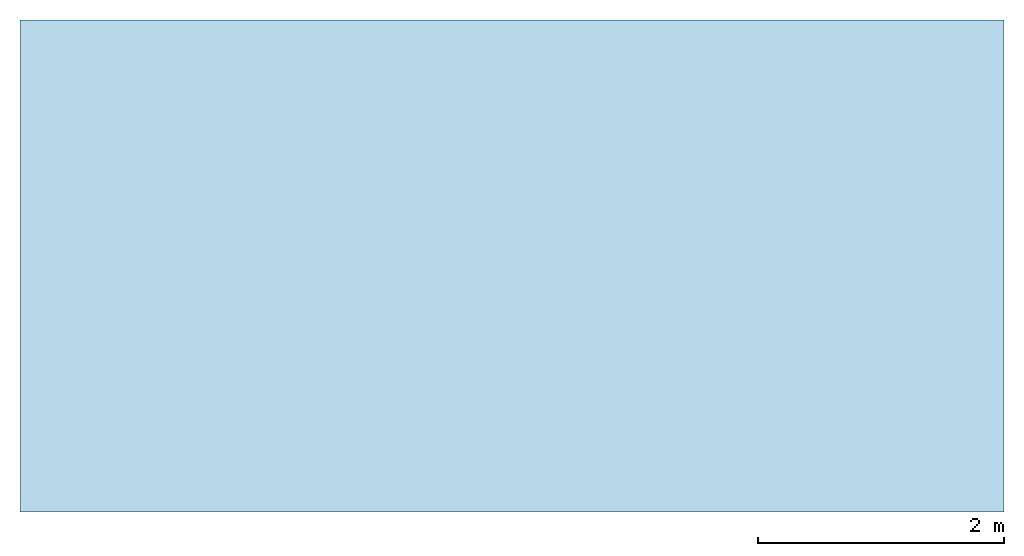
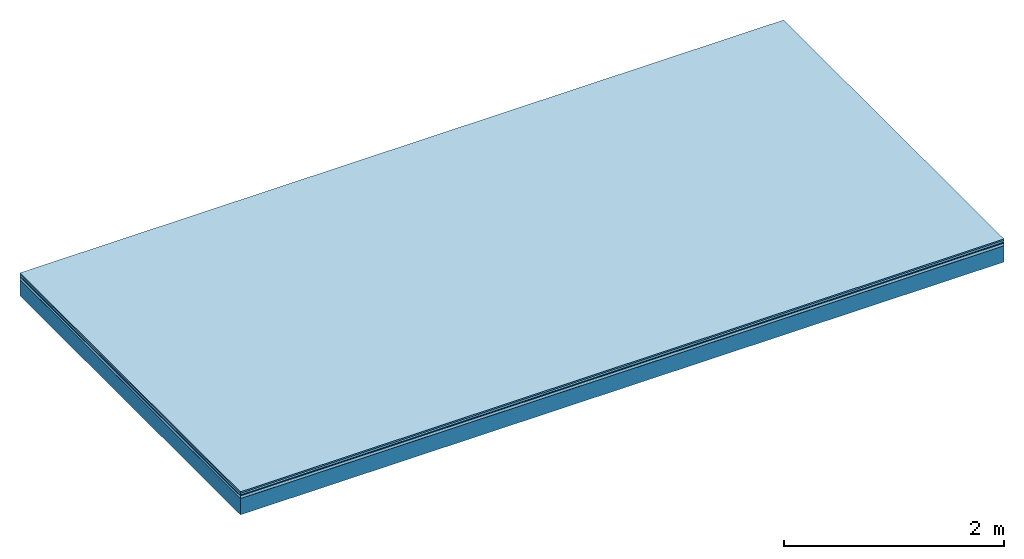
# One storey: 5 plates, 1 member, 1 element without a shape of its own.
"""IFC4 building model written with IfcOpenShell, lengths in metres."""

from ifc_helpers import new_model, si_unit, derived_unit, direction, frame, frame_2d, origin, origin_with_axes, place, context, project, spatial, rectangle, extrude, material, layer, layer_set, type_object, element, aggregate, save


model = new_model("IFC4")

# Units and contexts
plan_context = context("Plan", 3, precision=1e-05, world=origin(), true_north=direction((0.0, 1.0)))
model_context = context("Model", 3, precision=1e-05, world=origin(), true_north=direction((0.0, 1.0)))
ifc_project = project(units=[si_unit("LENGTHUNIT", "METRE"), derived_unit("SOUNDPRESSUREUNIT", [(si_unit("PRESSUREUNIT", "PASCAL", prefix="MICRO"), 0)]), si_unit("ENERGYUNIT", "JOULE", prefix="MEGA"), si_unit("MASSUNIT", "GRAM", prefix="KILO"), derived_unit("THERMALTRANSMITTANCEUNIT", [(si_unit("POWERUNIT", "WATT"), 1), (si_unit("AREAUNIT", "SQUARE_METRE"), -1), (si_unit("THERMODYNAMICTEMPERATUREUNIT", "KELVIN"), -1)]), derived_unit("AREADENSITYUNIT", [(si_unit("MASSUNIT", "GRAM", prefix="KILO"), 1), (si_unit("AREAUNIT", "SQUARE_METRE"), -1)]), derived_unit("USERDEFINED", [(si_unit("ENERGYUNIT", "JOULE", prefix="MEGA"), 1), (si_unit("AREAUNIT", "SQUARE_METRE"), -1)])], contexts=[plan_context, model_context])

# Site, building, storey
site = spatial("IfcSite", under=ifc_project)
building_placement = place(None, origin())
building = spatial("IfcBuilding", under=site, at=building_placement)
storey_placement = place(building_placement, origin())
storey = spatial("IfcBuildingStorey", under=building, at=storey_placement)

# Slab, member, plates
ifc_material_1 = material(Category="11.013")
ifc_layer_1 = layer(ifc_material_1, 0.015, Name="Flooring")
ifc_material_2 = material(Category="03.007")
ifc_layer_2 = layer(ifc_material_2, 0.02, Name="On-material")
ifc_material_3 = material(Name="Wood fiber generic product", Category="10.009")
ifc_layer_3 = layer(ifc_material_3, 0.01, Name="Impact sound insulation")
ifc_material_4 = material(Name="with broken")
ifc_layer_4 = layer(ifc_material_4, 0.03, Name="on Supporting structure")
ifc_material_5 = material(Name="protection", Category="09.007")
ifc_layer_5 = layer(ifc_material_5, 0.0005, Name="Sub-floor")
ifc_material_6 = material(Name="no composite action")
ifc_layer_6 = layer(ifc_material_6, 0.0, Name="Bond")
ifc_layer_7 = layer(None, 0.18, Name="Supporting structure")
ifc_layer_set = layer_set([ifc_layer_1, ifc_layer_2, ifc_layer_3, ifc_layer_4, ifc_layer_5, ifc_layer_6, ifc_layer_7])
slab_type = type_object("IfcSlabType", Name="A2045", PredefinedType="NOTDEFINED", material=ifc_layer_set)
slab_placement = place(None, frame((0.0, 0.0, 0.0), z_axis=(0.0, 0.0, -1.0), x_axis=(1.0, 0.0, 0.0)))
slab = element("IfcSlab", 1, at=slab_placement, inside=storey, type_object=slab_type, material=ifc_layer_set, Name="Slab #1")
ifc_material_7 = material(Name="Solid timber panel")
member_placement = place(slab_placement, origin())
member = element("IfcMember", 2, at=member_placement, material=ifc_material_7, Name="Supporting structure", context=plan_context, shape_type="SweptSolid", body=[
    extrude(rectangle(XDim=1.0, YDim=0.18, at=frame_2d((0.5, 0.09), x_axis=(1.0, 0.0))), frame((0.0, 4.0, 0.0755), z_axis=(0.0, -1.0, 0.0), x_axis=(1.0, 0.0, 0.0)), (0.0, 0.0, 1.0), 4.0),
    extrude(rectangle(XDim=1.0, YDim=0.18, at=frame_2d((0.5, 0.09), x_axis=(1.0, 0.0))), frame((1.0, 4.0, 0.0755), z_axis=(0.0, -1.0, 0.0), x_axis=(1.0, 0.0, 0.0)), (0.0, 0.0, 1.0), 4.0),
    extrude(rectangle(XDim=1.0, YDim=0.18, at=frame_2d((0.5, 0.09), x_axis=(1.0, 0.0))), frame((2.0, 4.0, 0.0755), z_axis=(0.0, -1.0, 0.0), x_axis=(1.0, 0.0, 0.0)), (0.0, 0.0, 1.0), 4.0),
    extrude(rectangle(XDim=1.0, YDim=0.18, at=frame_2d((0.5, 0.09), x_axis=(1.0, 0.0))), frame((3.0, 4.0, 0.0755), z_axis=(0.0, -1.0, 0.0), x_axis=(1.0, 0.0, 0.0)), (0.0, 0.0, 1.0), 4.0),
    extrude(rectangle(XDim=1.0, YDim=0.18, at=frame_2d((0.5, 0.09), x_axis=(1.0, 0.0))), frame((4.0, 4.0, 0.0755), z_axis=(0.0, -1.0, 0.0), x_axis=(1.0, 0.0, 0.0)), (0.0, 0.0, 1.0), 4.0),
    extrude(rectangle(XDim=1.0, YDim=0.18, at=frame_2d((0.5, 0.09), x_axis=(1.0, 0.0))), frame((5.0, 4.0, 0.0755), z_axis=(0.0, -1.0, 0.0), x_axis=(1.0, 0.0, 0.0)), (0.0, 0.0, 1.0), 4.0),
    extrude(rectangle(XDim=1.0, YDim=0.18, at=frame_2d((0.5, 0.09), x_axis=(1.0, 0.0))), frame((6.0, 4.0, 0.0755), z_axis=(0.0, -1.0, 0.0), x_axis=(1.0, 0.0, 0.0)), (0.0, 0.0, 1.0), 4.0),
    extrude(rectangle(XDim=1.0, YDim=0.18, at=frame_2d((0.5, 0.09), x_axis=(1.0, 0.0))), frame((7.0, 4.0, 0.0755), z_axis=(0.0, -1.0, 0.0), x_axis=(1.0, 0.0, 0.0)), (0.0, 0.0, 1.0), 4.0),
])
plate_1_placement = place(slab_placement, origin())
plate_1 = element("IfcPlate", 3, at=plate_1_placement, material=ifc_material_1, Name="Flooring", context=plan_context, shape_type="SweptSolid", body=[
    extrude(rectangle(XDim=8.0, YDim=4.0, at=frame_2d((4.0, 2.0), x_axis=(1.0, 0.0))), origin_with_axes(), (0.0, 0.0, 1.0), 0.015),
])
plate_2_placement = place(slab_placement, origin())
plate_2 = element("IfcPlate", 4, at=plate_2_placement, material=ifc_material_2, Name="On-material", context=plan_context, shape_type="SweptSolid", body=[
    extrude(rectangle(XDim=8.0, YDim=4.0, at=frame_2d((4.0, 2.0), x_axis=(1.0, 0.0))), frame((0.0, 0.0, 0.015), z_axis=(0.0, 0.0, 1.0), x_axis=(1.0, 0.0, 0.0)), (0.0, 0.0, 1.0), 0.02),
])
plate_3_placement = place(slab_placement, origin())
plate_3 = element("IfcPlate", 5, at=plate_3_placement, material=ifc_material_3, Name="Impact sound insulation", context=plan_context, shape_type="SweptSolid", body=[
    extrude(rectangle(XDim=8.0, YDim=4.0, at=frame_2d((4.0, 2.0), x_axis=(1.0, 0.0))), frame((0.0, 0.0, 0.035), z_axis=(0.0, 0.0, 1.0), x_axis=(1.0, 0.0, 0.0)), (0.0, 0.0, 1.0), 0.01),
])
plate_4_placement = place(slab_placement, origin())
plate_4 = element("IfcPlate", 6, at=plate_4_placement, material=ifc_material_4, Name="on Supporting structure", context=plan_context, shape_type="SweptSolid", body=[
    extrude(rectangle(XDim=8.0, YDim=4.0, at=frame_2d((4.0, 2.0), x_axis=(1.0, 0.0))), frame((0.0, 0.0, 0.045), z_axis=(0.0, 0.0, 1.0), x_axis=(1.0, 0.0, 0.0)), (0.0, 0.0, 1.0), 0.03),
])
plate_5_placement = place(slab_placement, origin())
plate_5 = element("IfcPlate", 7, at=plate_5_placement, material=ifc_material_5, Name="Sub-floor", context=plan_context, shape_type="SweptSolid", body=[
    extrude(rectangle(XDim=8.0, YDim=4.0, at=frame_2d((4.0, 2.0), x_axis=(1.0, 0.0))), frame((0.0, 0.0, 0.075), z_axis=(0.0, 0.0, 1.0), x_axis=(1.0, 0.0, 0.0)), (0.0, 0.0, 1.0), 0.0005),
])
aggregate(slab, [plate_1, plate_2, plate_3, plate_4, plate_5, member])

save(model, "model.ifc")
